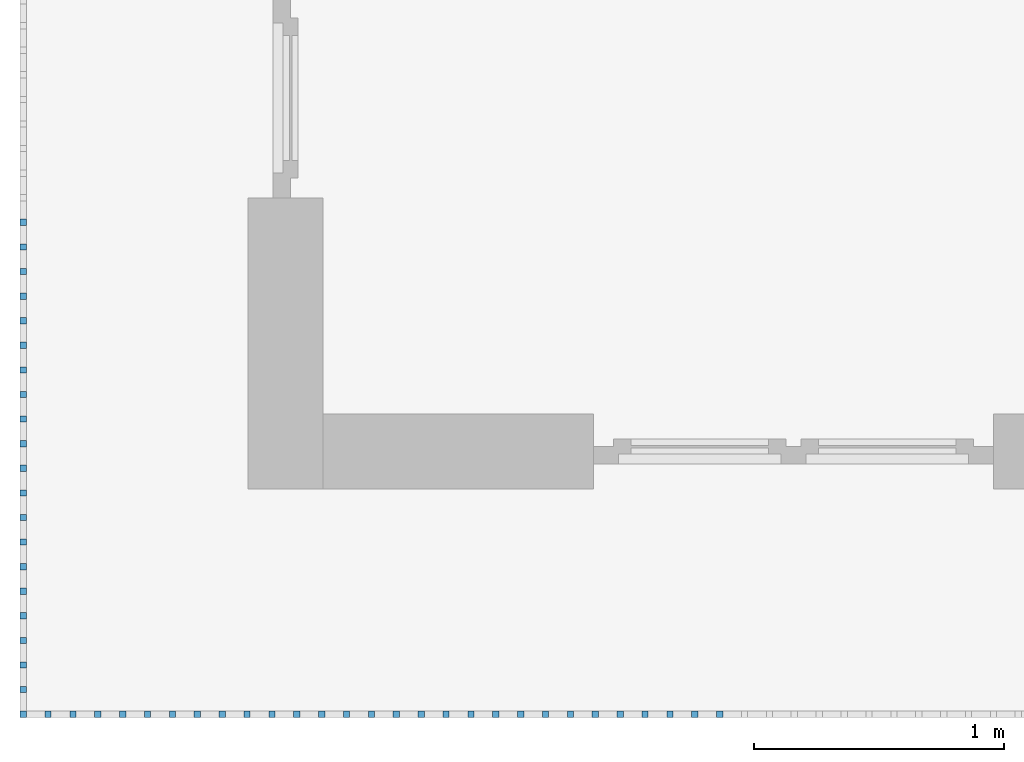
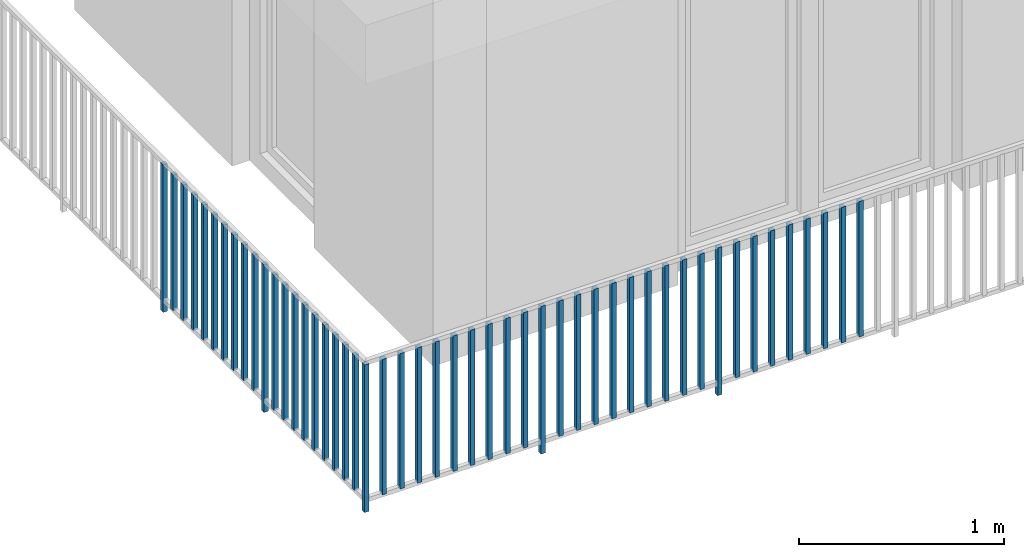
# One storey, part 32 of 54: 49 building element parts, 1 element without a shape of its own.
"""IFC4 building model written with IfcOpenShell, lengths in metres."""

from ifc_helpers import new_model, entity, si_unit, converted_unit, derived_unit, direction, frame, origin_with_axes, place, context, subcontext, project, spatial, polygons, material, type_object, element, aggregate, save


model = new_model("IFC4")

# Units and contexts
model_context = context("Model", 3, precision=1e-05, world=origin_with_axes(), true_north=direction((0.0, 1.0)))
body_context = subcontext(model_context, "Body", "Model", "MODEL_VIEW")
ifc_project = project(units=[si_unit("LENGTHUNIT", "METRE"), si_unit("AREAUNIT", "SQUARE_METRE"), si_unit("VOLUMEUNIT", "CUBIC_METRE"), converted_unit("PLANEANGLEUNIT", "DEGREE", entity("IfcPlaneAngleMeasure", 0.0174532925199), si_unit("PLANEANGLEUNIT", "RADIAN"), dimensions=[0, 0, 0, 0, 0, 0, 0]), converted_unit("TIMEUNIT", "Year", entity("IfcTimeMeasure", 31556926.0), si_unit("TIMEUNIT", "SECOND"), dimensions=[0, 0, 1, 0, 0, 0, 0]), si_unit("MASSUNIT", "GRAM", prefix="KILO"), si_unit("THERMODYNAMICTEMPERATUREUNIT", "DEGREE_CELSIUS"), si_unit("LUMINOUSINTENSITYUNIT", "LUMEN"), si_unit("ENERGYUNIT", "JOULE", prefix="MEGA"), derived_unit("THERMALCONDUCTANCEUNIT", [(si_unit("POWERUNIT", "WATT"), 1), (si_unit("LENGTHUNIT", "METRE"), -1), (si_unit("THERMODYNAMICTEMPERATUREUNIT", "KELVIN"), -1)]), derived_unit("SPECIFICHEATCAPACITYUNIT", [(si_unit("ENERGYUNIT", "JOULE"), 1), (si_unit("MASSUNIT", "GRAM", prefix="KILO"), -1), (si_unit("THERMODYNAMICTEMPERATUREUNIT", "KELVIN"), -1)]), derived_unit("MASSDENSITYUNIT", [(si_unit("MASSUNIT", "GRAM", prefix="KILO"), 1), (si_unit("VOLUMEUNIT", "CUBIC_METRE"), -1)])], contexts=[model_context])

# Site, building, storey, space
site_placement = place(None, origin_with_axes())
site = spatial("IfcSite", under=ifc_project, at=site_placement, CompositionType="ELEMENT")
building_placement = place(site_placement, origin_with_axes())
building = spatial("IfcBuilding", under=site, at=building_placement, CompositionType="ELEMENT")
storey_placement = place(building_placement, frame((0.0, 0.0, 9.18), z_axis=(0.0, 0.0, 1.0), x_axis=(1.0, 0.0, 0.0)))
storey = spatial("IfcBuildingStorey", under=building, at=storey_placement, Name="3. Geschoss", CompositionType="ELEMENT", Elevation=9.18)
space_placement = place(storey_placement, frame((10.2378006196, 9.82118769833, 0.0), z_axis=(0.0, 0.0, 1.0), x_axis=(-1.0, 0.0, 0.0)))
space = spatial("IfcSpace", under=storey, at=space_placement, CompositionType="ELEMENT", PredefinedType="EXTERNAL")

# Railing, building element parts
railing_type = type_object("IfcRailingType", PredefinedType="NOTDEFINED")
railing_placement = place(space_placement, frame((0.0, -7.06315681498e-08, 0.0), z_axis=(0.0, 0.0, 1.0), x_axis=(-1.0, 0.0, 0.0)))
railing = element("IfcRailing", 1, at=railing_placement, inside=space, type_object=railing_type, PredefinedType="NOTDEFINED")
ifc_material = material()
building_element_part_1_placement = place(railing_placement, origin_with_axes())
building_element_part_1 = element("IfcBuildingElementPart", 2, at=building_element_part_1_placement, material=ifc_material, PredefinedType="NOTDEFINED", context=body_context, shape_type="Tessellation", body=[
    polygons([(-22.8925, -20.6625, 0.0), (-22.8675, -20.6625, 0.0), (-22.8675, -20.6625, 0.88), (-22.8925, -20.6625, 0.88), (-22.8925, -20.6375, 0.0), (-22.8675, -20.6375, 0.0), (-22.8675, -20.6375, 0.88), (-22.8925, -20.6375, 0.88)], [[[1, 2, 3, 4]], [[1, 5, 6, 2]], [[2, 6, 7, 3]], [[4, 3, 7, 8]], [[5, 1, 4, 8]], [[6, 5, 8, 7]]], closed=True),
])
building_element_part_2_placement = place(railing_placement, origin_with_axes())
building_element_part_2 = element("IfcBuildingElementPart", 3, at=building_element_part_2_placement, material=ifc_material, PredefinedType="NOTDEFINED", context=body_context, shape_type="Tessellation", body=[
    polygons([(-22.8925, -18.6958333333, 0.0), (-22.8675, -18.6958333333, 0.0), (-22.8675, -18.6958333333, 0.88), (-22.8925, -18.6958333333, 0.88), (-22.8925, -18.6708333333, 0.0), (-22.8675, -18.6708333333, 0.0), (-22.8675, -18.6708333333, 0.88), (-22.8925, -18.6708333333, 0.88)], [[[1, 2, 3, 4]], [[1, 5, 6, 2]], [[2, 6, 7, 3]], [[4, 3, 7, 8]], [[5, 1, 4, 8]], [[6, 5, 8, 7]]], closed=True),
])
building_element_part_3_placement = place(railing_placement, origin_with_axes())
building_element_part_3 = element("IfcBuildingElementPart", 4, at=building_element_part_3_placement, material=ifc_material, PredefinedType="NOTDEFINED", context=body_context, shape_type="Tessellation", body=[
    polygons([(-22.8925, -18.7941666667, 0.07), (-22.8675, -18.7941666667, 0.07), (-22.8675, -18.7941666667, 0.8775), (-22.8925, -18.7941666667, 0.8775), (-22.8925, -18.7691666667, 0.07), (-22.8675, -18.7691666667, 0.07), (-22.8675, -18.7691666667, 0.8775), (-22.8925, -18.7691666667, 0.8775)], [[[1, 2, 3, 4]], [[1, 5, 6, 2]], [[2, 6, 7, 3]], [[4, 3, 7, 8]], [[5, 1, 4, 8]], [[6, 5, 8, 7]]], closed=True),
])
building_element_part_4_placement = place(railing_placement, origin_with_axes())
building_element_part_4 = element("IfcBuildingElementPart", 5, at=building_element_part_4_placement, material=ifc_material, PredefinedType="NOTDEFINED", context=body_context, shape_type="Tessellation", body=[
    polygons([(-22.8925, -18.8925, 0.07), (-22.8675, -18.8925, 0.07), (-22.8675, -18.8925, 0.8775), (-22.8925, -18.8925, 0.8775), (-22.8925, -18.8675, 0.07), (-22.8675, -18.8675, 0.07), (-22.8675, -18.8675, 0.8775), (-22.8925, -18.8675, 0.8775)], [[[1, 2, 3, 4]], [[1, 5, 6, 2]], [[2, 6, 7, 3]], [[4, 3, 7, 8]], [[5, 1, 4, 8]], [[6, 5, 8, 7]]], closed=True),
])
building_element_part_5_placement = place(railing_placement, origin_with_axes())
building_element_part_5 = element("IfcBuildingElementPart", 6, at=building_element_part_5_placement, material=ifc_material, PredefinedType="NOTDEFINED", context=body_context, shape_type="Tessellation", body=[
    polygons([(-22.8925, -18.9908333333, 0.07), (-22.8675, -18.9908333333, 0.07), (-22.8675, -18.9908333333, 0.8775), (-22.8925, -18.9908333333, 0.8775), (-22.8925, -18.9658333333, 0.07), (-22.8675, -18.9658333333, 0.07), (-22.8675, -18.9658333333, 0.8775), (-22.8925, -18.9658333333, 0.8775)], [[[1, 2, 3, 4]], [[1, 5, 6, 2]], [[2, 6, 7, 3]], [[4, 3, 7, 8]], [[5, 1, 4, 8]], [[6, 5, 8, 7]]], closed=True),
])
building_element_part_6_placement = place(railing_placement, origin_with_axes())
building_element_part_6 = element("IfcBuildingElementPart", 7, at=building_element_part_6_placement, material=ifc_material, PredefinedType="NOTDEFINED", context=body_context, shape_type="Tessellation", body=[
    polygons([(-22.8925, -19.0891666667, 0.07), (-22.8675, -19.0891666667, 0.07), (-22.8675, -19.0891666667, 0.8775), (-22.8925, -19.0891666667, 0.8775), (-22.8925, -19.0641666667, 0.07), (-22.8675, -19.0641666667, 0.07), (-22.8675, -19.0641666667, 0.8775), (-22.8925, -19.0641666667, 0.8775)], [[[1, 2, 3, 4]], [[1, 5, 6, 2]], [[2, 6, 7, 3]], [[4, 3, 7, 8]], [[5, 1, 4, 8]], [[6, 5, 8, 7]]], closed=True),
])
building_element_part_7_placement = place(railing_placement, origin_with_axes())
building_element_part_7 = element("IfcBuildingElementPart", 8, at=building_element_part_7_placement, material=ifc_material, PredefinedType="NOTDEFINED", context=body_context, shape_type="Tessellation", body=[
    polygons([(-22.8925, -19.1875, 0.07), (-22.8675, -19.1875, 0.07), (-22.8675, -19.1875, 0.8775), (-22.8925, -19.1875, 0.8775), (-22.8925, -19.1625, 0.07), (-22.8675, -19.1625, 0.07), (-22.8675, -19.1625, 0.8775), (-22.8925, -19.1625, 0.8775)], [[[1, 2, 3, 4]], [[1, 5, 6, 2]], [[2, 6, 7, 3]], [[4, 3, 7, 8]], [[5, 1, 4, 8]], [[6, 5, 8, 7]]], closed=True),
])
building_element_part_8_placement = place(railing_placement, origin_with_axes())
building_element_part_8 = element("IfcBuildingElementPart", 9, at=building_element_part_8_placement, material=ifc_material, PredefinedType="NOTDEFINED", context=body_context, shape_type="Tessellation", body=[
    polygons([(-22.8925, -19.2858333333, 0.07), (-22.8675, -19.2858333333, 0.07), (-22.8675, -19.2858333333, 0.8775), (-22.8925, -19.2858333333, 0.8775), (-22.8925, -19.2608333333, 0.07), (-22.8675, -19.2608333333, 0.07), (-22.8675, -19.2608333333, 0.8775), (-22.8925, -19.2608333333, 0.8775)], [[[1, 2, 3, 4]], [[1, 5, 6, 2]], [[2, 6, 7, 3]], [[4, 3, 7, 8]], [[5, 1, 4, 8]], [[6, 5, 8, 7]]], closed=True),
])
building_element_part_9_placement = place(railing_placement, origin_with_axes())
building_element_part_9 = element("IfcBuildingElementPart", 10, at=building_element_part_9_placement, material=ifc_material, PredefinedType="NOTDEFINED", context=body_context, shape_type="Tessellation", body=[
    polygons([(-22.8925, -19.3841666667, 0.07), (-22.8675, -19.3841666667, 0.07), (-22.8675, -19.3841666667, 0.8775), (-22.8925, -19.3841666667, 0.8775), (-22.8925, -19.3591666667, 0.07), (-22.8675, -19.3591666667, 0.07), (-22.8675, -19.3591666667, 0.8775), (-22.8925, -19.3591666667, 0.8775)], [[[1, 2, 3, 4]], [[1, 5, 6, 2]], [[2, 6, 7, 3]], [[4, 3, 7, 8]], [[5, 1, 4, 8]], [[6, 5, 8, 7]]], closed=True),
])
building_element_part_10_placement = place(railing_placement, origin_with_axes())
building_element_part_10 = element("IfcBuildingElementPart", 11, at=building_element_part_10_placement, material=ifc_material, PredefinedType="NOTDEFINED", context=body_context, shape_type="Tessellation", body=[
    polygons([(-22.8925, -19.4825, 0.07), (-22.8675, -19.4825, 0.07), (-22.8675, -19.4825, 0.8775), (-22.8925, -19.4825, 0.8775), (-22.8925, -19.4575, 0.07), (-22.8675, -19.4575, 0.07), (-22.8675, -19.4575, 0.8775), (-22.8925, -19.4575, 0.8775)], [[[1, 2, 3, 4]], [[1, 5, 6, 2]], [[2, 6, 7, 3]], [[4, 3, 7, 8]], [[5, 1, 4, 8]], [[6, 5, 8, 7]]], closed=True),
])
building_element_part_11_placement = place(railing_placement, origin_with_axes())
building_element_part_11 = element("IfcBuildingElementPart", 12, at=building_element_part_11_placement, material=ifc_material, PredefinedType="NOTDEFINED", context=body_context, shape_type="Tessellation", body=[
    polygons([(-22.8925, -19.5808333333, 0.07), (-22.8675, -19.5808333333, 0.07), (-22.8675, -19.5808333333, 0.8775), (-22.8925, -19.5808333333, 0.8775), (-22.8925, -19.5558333333, 0.07), (-22.8675, -19.5558333333, 0.07), (-22.8675, -19.5558333333, 0.8775), (-22.8925, -19.5558333333, 0.8775)], [[[1, 2, 3, 4]], [[1, 5, 6, 2]], [[2, 6, 7, 3]], [[4, 3, 7, 8]], [[5, 1, 4, 8]], [[6, 5, 8, 7]]], closed=True),
])
building_element_part_12_placement = place(railing_placement, origin_with_axes())
building_element_part_12 = element("IfcBuildingElementPart", 13, at=building_element_part_12_placement, material=ifc_material, PredefinedType="NOTDEFINED", context=body_context, shape_type="Tessellation", body=[
    polygons([(-22.8925, -19.6791666667, 0.0), (-22.8675, -19.6791666667, 0.0), (-22.8675, -19.6791666667, 0.88), (-22.8925, -19.6791666667, 0.88), (-22.8925, -19.6541666667, 0.0), (-22.8675, -19.6541666667, 0.0), (-22.8675, -19.6541666667, 0.88), (-22.8925, -19.6541666667, 0.88)], [[[1, 2, 3, 4]], [[1, 5, 6, 2]], [[2, 6, 7, 3]], [[4, 3, 7, 8]], [[5, 1, 4, 8]], [[6, 5, 8, 7]]], closed=True),
])
building_element_part_13_placement = place(railing_placement, origin_with_axes())
building_element_part_13 = element("IfcBuildingElementPart", 14, at=building_element_part_13_placement, material=ifc_material, PredefinedType="NOTDEFINED", context=body_context, shape_type="Tessellation", body=[
    polygons([(-22.8925, -19.7775, 0.07), (-22.8675, -19.7775, 0.07), (-22.8675, -19.7775, 0.8775), (-22.8925, -19.7775, 0.8775), (-22.8925, -19.7525, 0.07), (-22.8675, -19.7525, 0.07), (-22.8675, -19.7525, 0.8775), (-22.8925, -19.7525, 0.8775)], [[[1, 2, 3, 4]], [[1, 5, 6, 2]], [[2, 6, 7, 3]], [[4, 3, 7, 8]], [[5, 1, 4, 8]], [[6, 5, 8, 7]]], closed=True),
])
building_element_part_14_placement = place(railing_placement, origin_with_axes())
building_element_part_14 = element("IfcBuildingElementPart", 15, at=building_element_part_14_placement, material=ifc_material, PredefinedType="NOTDEFINED", context=body_context, shape_type="Tessellation", body=[
    polygons([(-22.8925, -19.8758333333, 0.07), (-22.8675, -19.8758333333, 0.07), (-22.8675, -19.8758333333, 0.8775), (-22.8925, -19.8758333333, 0.8775), (-22.8925, -19.8508333333, 0.07), (-22.8675, -19.8508333333, 0.07), (-22.8675, -19.8508333333, 0.8775), (-22.8925, -19.8508333333, 0.8775)], [[[1, 2, 3, 4]], [[1, 5, 6, 2]], [[2, 6, 7, 3]], [[4, 3, 7, 8]], [[5, 1, 4, 8]], [[6, 5, 8, 7]]], closed=True),
])
building_element_part_15_placement = place(railing_placement, origin_with_axes())
building_element_part_15 = element("IfcBuildingElementPart", 16, at=building_element_part_15_placement, material=ifc_material, PredefinedType="NOTDEFINED", context=body_context, shape_type="Tessellation", body=[
    polygons([(-22.8925, -19.9741666667, 0.07), (-22.8675, -19.9741666667, 0.07), (-22.8675, -19.9741666667, 0.8775), (-22.8925, -19.9741666667, 0.8775), (-22.8925, -19.9491666667, 0.07), (-22.8675, -19.9491666667, 0.07), (-22.8675, -19.9491666667, 0.8775), (-22.8925, -19.9491666667, 0.8775)], [[[1, 2, 3, 4]], [[1, 5, 6, 2]], [[2, 6, 7, 3]], [[4, 3, 7, 8]], [[5, 1, 4, 8]], [[6, 5, 8, 7]]], closed=True),
])
building_element_part_16_placement = place(railing_placement, origin_with_axes())
building_element_part_16 = element("IfcBuildingElementPart", 17, at=building_element_part_16_placement, material=ifc_material, PredefinedType="NOTDEFINED", context=body_context, shape_type="Tessellation", body=[
    polygons([(-22.8925, -20.0725, 0.07), (-22.8675, -20.0725, 0.07), (-22.8675, -20.0725, 0.8775), (-22.8925, -20.0725, 0.8775), (-22.8925, -20.0475, 0.07), (-22.8675, -20.0475, 0.07), (-22.8675, -20.0475, 0.8775), (-22.8925, -20.0475, 0.8775)], [[[1, 2, 3, 4]], [[1, 5, 6, 2]], [[2, 6, 7, 3]], [[4, 3, 7, 8]], [[5, 1, 4, 8]], [[6, 5, 8, 7]]], closed=True),
])
building_element_part_17_placement = place(railing_placement, origin_with_axes())
building_element_part_17 = element("IfcBuildingElementPart", 18, at=building_element_part_17_placement, material=ifc_material, PredefinedType="NOTDEFINED", context=body_context, shape_type="Tessellation", body=[
    polygons([(-22.8925, -20.1708333333, 0.07), (-22.8675, -20.1708333333, 0.07), (-22.8675, -20.1708333333, 0.8775), (-22.8925, -20.1708333333, 0.8775), (-22.8925, -20.1458333333, 0.07), (-22.8675, -20.1458333333, 0.07), (-22.8675, -20.1458333333, 0.8775), (-22.8925, -20.1458333333, 0.8775)], [[[1, 2, 3, 4]], [[1, 5, 6, 2]], [[2, 6, 7, 3]], [[4, 3, 7, 8]], [[5, 1, 4, 8]], [[6, 5, 8, 7]]], closed=True),
])
building_element_part_18_placement = place(railing_placement, origin_with_axes())
building_element_part_18 = element("IfcBuildingElementPart", 19, at=building_element_part_18_placement, material=ifc_material, PredefinedType="NOTDEFINED", context=body_context, shape_type="Tessellation", body=[
    polygons([(-22.8925, -20.2691666667, 0.07), (-22.8675, -20.2691666667, 0.07), (-22.8675, -20.2691666667, 0.8775), (-22.8925, -20.2691666667, 0.8775), (-22.8925, -20.2441666667, 0.07), (-22.8675, -20.2441666667, 0.07), (-22.8675, -20.2441666667, 0.8775), (-22.8925, -20.2441666667, 0.8775)], [[[1, 2, 3, 4]], [[1, 5, 6, 2]], [[2, 6, 7, 3]], [[4, 3, 7, 8]], [[5, 1, 4, 8]], [[6, 5, 8, 7]]], closed=True),
])
building_element_part_19_placement = place(railing_placement, origin_with_axes())
building_element_part_19 = element("IfcBuildingElementPart", 20, at=building_element_part_19_placement, material=ifc_material, PredefinedType="NOTDEFINED", context=body_context, shape_type="Tessellation", body=[
    polygons([(-22.8925, -20.3675, 0.07), (-22.8675, -20.3675, 0.07), (-22.8675, -20.3675, 0.8775), (-22.8925, -20.3675, 0.8775), (-22.8925, -20.3425, 0.07), (-22.8675, -20.3425, 0.07), (-22.8675, -20.3425, 0.8775), (-22.8925, -20.3425, 0.8775)], [[[1, 2, 3, 4]], [[1, 5, 6, 2]], [[2, 6, 7, 3]], [[4, 3, 7, 8]], [[5, 1, 4, 8]], [[6, 5, 8, 7]]], closed=True),
])
building_element_part_20_placement = place(railing_placement, origin_with_axes())
building_element_part_20 = element("IfcBuildingElementPart", 21, at=building_element_part_20_placement, material=ifc_material, PredefinedType="NOTDEFINED", context=body_context, shape_type="Tessellation", body=[
    polygons([(-22.8925, -20.4658333333, 0.07), (-22.8675, -20.4658333333, 0.07), (-22.8675, -20.4658333333, 0.8775), (-22.8925, -20.4658333333, 0.8775), (-22.8925, -20.4408333333, 0.07), (-22.8675, -20.4408333333, 0.07), (-22.8675, -20.4408333333, 0.8775), (-22.8925, -20.4408333333, 0.8775)], [[[1, 2, 3, 4]], [[1, 5, 6, 2]], [[2, 6, 7, 3]], [[4, 3, 7, 8]], [[5, 1, 4, 8]], [[6, 5, 8, 7]]], closed=True),
])
building_element_part_21_placement = place(railing_placement, origin_with_axes())
building_element_part_21 = element("IfcBuildingElementPart", 22, at=building_element_part_21_placement, material=ifc_material, PredefinedType="NOTDEFINED", context=body_context, shape_type="Tessellation", body=[
    polygons([(-22.8925, -20.5641666667, 0.07), (-22.8675, -20.5641666667, 0.07), (-22.8675, -20.5641666667, 0.8775), (-22.8925, -20.5641666667, 0.8775), (-22.8925, -20.5391666667, 0.07), (-22.8675, -20.5391666667, 0.07), (-22.8675, -20.5391666667, 0.8775), (-22.8925, -20.5391666667, 0.8775)], [[[1, 2, 3, 4]], [[1, 5, 6, 2]], [[2, 6, 7, 3]], [[4, 3, 7, 8]], [[5, 1, 4, 8]], [[6, 5, 8, 7]]], closed=True),
])
building_element_part_22_placement = place(railing_placement, origin_with_axes())
building_element_part_22 = element("IfcBuildingElementPart", 23, at=building_element_part_22_placement, material=ifc_material, PredefinedType="NOTDEFINED", context=body_context, shape_type="Tessellation", body=[
    polygons([(-22.7680217391, -20.6625, 0.07), (-22.7680217391, -20.6375, 0.07), (-22.7680217391, -20.6375, 0.8775), (-22.7680217391, -20.6625, 0.8775), (-22.7930217391, -20.6625, 0.07), (-22.7930217391, -20.6375, 0.07), (-22.7930217391, -20.6375, 0.8775), (-22.7930217391, -20.6625, 0.8775)], [[[1, 2, 3, 4]], [[1, 5, 6, 2]], [[2, 6, 7, 3]], [[4, 3, 7, 8]], [[5, 1, 4, 8]], [[6, 5, 8, 7]]], closed=True),
])
building_element_part_23_placement = place(railing_placement, origin_with_axes())
building_element_part_23 = element("IfcBuildingElementPart", 24, at=building_element_part_23_placement, material=ifc_material, PredefinedType="NOTDEFINED", context=body_context, shape_type="Tessellation", body=[
    polygons([(-22.6685434783, -20.6625, 0.07), (-22.6685434783, -20.6375, 0.07), (-22.6685434783, -20.6375, 0.8775), (-22.6685434783, -20.6625, 0.8775), (-22.6935434783, -20.6625, 0.07), (-22.6935434783, -20.6375, 0.07), (-22.6935434783, -20.6375, 0.8775), (-22.6935434783, -20.6625, 0.8775)], [[[1, 2, 3, 4]], [[1, 5, 6, 2]], [[2, 6, 7, 3]], [[4, 3, 7, 8]], [[5, 1, 4, 8]], [[6, 5, 8, 7]]], closed=True),
])
building_element_part_24_placement = place(railing_placement, origin_with_axes())
building_element_part_24 = element("IfcBuildingElementPart", 25, at=building_element_part_24_placement, material=ifc_material, PredefinedType="NOTDEFINED", context=body_context, shape_type="Tessellation", body=[
    polygons([(-22.5690652174, -20.6625, 0.07), (-22.5690652174, -20.6375, 0.07), (-22.5690652174, -20.6375, 0.8775), (-22.5690652174, -20.6625, 0.8775), (-22.5940652174, -20.6625, 0.07), (-22.5940652174, -20.6375, 0.07), (-22.5940652174, -20.6375, 0.8775), (-22.5940652174, -20.6625, 0.8775)], [[[1, 2, 3, 4]], [[1, 5, 6, 2]], [[2, 6, 7, 3]], [[4, 3, 7, 8]], [[5, 1, 4, 8]], [[6, 5, 8, 7]]], closed=True),
])
building_element_part_25_placement = place(railing_placement, origin_with_axes())
building_element_part_25 = element("IfcBuildingElementPart", 26, at=building_element_part_25_placement, material=ifc_material, PredefinedType="NOTDEFINED", context=body_context, shape_type="Tessellation", body=[
    polygons([(-22.4695869565, -20.6625, 0.07), (-22.4695869565, -20.6375, 0.07), (-22.4695869565, -20.6375, 0.8775), (-22.4695869565, -20.6625, 0.8775), (-22.4945869565, -20.6625, 0.07), (-22.4945869565, -20.6375, 0.07), (-22.4945869565, -20.6375, 0.8775), (-22.4945869565, -20.6625, 0.8775)], [[[1, 2, 3, 4]], [[1, 5, 6, 2]], [[2, 6, 7, 3]], [[4, 3, 7, 8]], [[5, 1, 4, 8]], [[6, 5, 8, 7]]], closed=True),
])
building_element_part_26_placement = place(railing_placement, origin_with_axes())
building_element_part_26 = element("IfcBuildingElementPart", 27, at=building_element_part_26_placement, material=ifc_material, PredefinedType="NOTDEFINED", context=body_context, shape_type="Tessellation", body=[
    polygons([(-22.3701086957, -20.6625, 0.07), (-22.3701086957, -20.6375, 0.07), (-22.3701086957, -20.6375, 0.8775), (-22.3701086957, -20.6625, 0.8775), (-22.3951086957, -20.6625, 0.07), (-22.3951086957, -20.6375, 0.07), (-22.3951086957, -20.6375, 0.8775), (-22.3951086957, -20.6625, 0.8775)], [[[1, 2, 3, 4]], [[1, 5, 6, 2]], [[2, 6, 7, 3]], [[4, 3, 7, 8]], [[5, 1, 4, 8]], [[6, 5, 8, 7]]], closed=True),
])
building_element_part_27_placement = place(railing_placement, origin_with_axes())
building_element_part_27 = element("IfcBuildingElementPart", 28, at=building_element_part_27_placement, material=ifc_material, PredefinedType="NOTDEFINED", context=body_context, shape_type="Tessellation", body=[
    polygons([(-22.2706304348, -20.6625, 0.07), (-22.2706304348, -20.6375, 0.07), (-22.2706304348, -20.6375, 0.8775), (-22.2706304348, -20.6625, 0.8775), (-22.2956304348, -20.6625, 0.07), (-22.2956304348, -20.6375, 0.07), (-22.2956304348, -20.6375, 0.8775), (-22.2956304348, -20.6625, 0.8775)], [[[1, 2, 3, 4]], [[1, 5, 6, 2]], [[2, 6, 7, 3]], [[4, 3, 7, 8]], [[5, 1, 4, 8]], [[6, 5, 8, 7]]], closed=True),
])
building_element_part_28_placement = place(railing_placement, origin_with_axes())
building_element_part_28 = element("IfcBuildingElementPart", 29, at=building_element_part_28_placement, material=ifc_material, PredefinedType="NOTDEFINED", context=body_context, shape_type="Tessellation", body=[
    polygons([(-22.1711521739, -20.6625, 0.07), (-22.1711521739, -20.6375, 0.07), (-22.1711521739, -20.6375, 0.8775), (-22.1711521739, -20.6625, 0.8775), (-22.1961521739, -20.6625, 0.07), (-22.1961521739, -20.6375, 0.07), (-22.1961521739, -20.6375, 0.8775), (-22.1961521739, -20.6625, 0.8775)], [[[1, 2, 3, 4]], [[1, 5, 6, 2]], [[2, 6, 7, 3]], [[4, 3, 7, 8]], [[5, 1, 4, 8]], [[6, 5, 8, 7]]], closed=True),
])
building_element_part_29_placement = place(railing_placement, origin_with_axes())
building_element_part_29 = element("IfcBuildingElementPart", 30, at=building_element_part_29_placement, material=ifc_material, PredefinedType="NOTDEFINED", context=body_context, shape_type="Tessellation", body=[
    polygons([(-22.071673913, -20.6625, 0.07), (-22.071673913, -20.6375, 0.07), (-22.071673913, -20.6375, 0.8775), (-22.071673913, -20.6625, 0.8775), (-22.096673913, -20.6625, 0.07), (-22.096673913, -20.6375, 0.07), (-22.096673913, -20.6375, 0.8775), (-22.096673913, -20.6625, 0.8775)], [[[1, 2, 3, 4]], [[1, 5, 6, 2]], [[2, 6, 7, 3]], [[4, 3, 7, 8]], [[5, 1, 4, 8]], [[6, 5, 8, 7]]], closed=True),
])
building_element_part_30_placement = place(railing_placement, origin_with_axes())
building_element_part_30 = element("IfcBuildingElementPart", 31, at=building_element_part_30_placement, material=ifc_material, PredefinedType="NOTDEFINED", context=body_context, shape_type="Tessellation", body=[
    polygons([(-21.9721956522, -20.6625, 0.07), (-21.9721956522, -20.6375, 0.07), (-21.9721956522, -20.6375, 0.8775), (-21.9721956522, -20.6625, 0.8775), (-21.9971956522, -20.6625, 0.07), (-21.9971956522, -20.6375, 0.07), (-21.9971956522, -20.6375, 0.8775), (-21.9971956522, -20.6625, 0.8775)], [[[1, 2, 3, 4]], [[1, 5, 6, 2]], [[2, 6, 7, 3]], [[4, 3, 7, 8]], [[5, 1, 4, 8]], [[6, 5, 8, 7]]], closed=True),
])
building_element_part_31_placement = place(railing_placement, origin_with_axes())
building_element_part_31 = element("IfcBuildingElementPart", 32, at=building_element_part_31_placement, material=ifc_material, PredefinedType="NOTDEFINED", context=body_context, shape_type="Tessellation", body=[
    polygons([(-21.8727173913, -20.6625, 0.0), (-21.8727173913, -20.6375, 0.0), (-21.8727173913, -20.6375, 0.88), (-21.8727173913, -20.6625, 0.88), (-21.8977173913, -20.6625, 0.0), (-21.8977173913, -20.6375, 0.0), (-21.8977173913, -20.6375, 0.88), (-21.8977173913, -20.6625, 0.88)], [[[1, 2, 3, 4]], [[1, 5, 6, 2]], [[2, 6, 7, 3]], [[4, 3, 7, 8]], [[5, 1, 4, 8]], [[6, 5, 8, 7]]], closed=True),
])
building_element_part_32_placement = place(railing_placement, origin_with_axes())
building_element_part_32 = element("IfcBuildingElementPart", 33, at=building_element_part_32_placement, material=ifc_material, PredefinedType="NOTDEFINED", context=body_context, shape_type="Tessellation", body=[
    polygons([(-21.7732391304, -20.6625, 0.07), (-21.7732391304, -20.6375, 0.07), (-21.7732391304, -20.6375, 0.8775), (-21.7732391304, -20.6625, 0.8775), (-21.7982391304, -20.6625, 0.07), (-21.7982391304, -20.6375, 0.07), (-21.7982391304, -20.6375, 0.8775), (-21.7982391304, -20.6625, 0.8775)], [[[1, 2, 3, 4]], [[1, 5, 6, 2]], [[2, 6, 7, 3]], [[4, 3, 7, 8]], [[5, 1, 4, 8]], [[6, 5, 8, 7]]], closed=True),
])
building_element_part_33_placement = place(railing_placement, origin_with_axes())
building_element_part_33 = element("IfcBuildingElementPart", 34, at=building_element_part_33_placement, material=ifc_material, PredefinedType="NOTDEFINED", context=body_context, shape_type="Tessellation", body=[
    polygons([(-21.6737608696, -20.6625, 0.07), (-21.6737608696, -20.6375, 0.07), (-21.6737608696, -20.6375, 0.8775), (-21.6737608696, -20.6625, 0.8775), (-21.6987608696, -20.6625, 0.07), (-21.6987608696, -20.6375, 0.07), (-21.6987608696, -20.6375, 0.8775), (-21.6987608696, -20.6625, 0.8775)], [[[1, 2, 3, 4]], [[1, 5, 6, 2]], [[2, 6, 7, 3]], [[4, 3, 7, 8]], [[5, 1, 4, 8]], [[6, 5, 8, 7]]], closed=True),
])
building_element_part_34_placement = place(railing_placement, origin_with_axes())
building_element_part_34 = element("IfcBuildingElementPart", 35, at=building_element_part_34_placement, material=ifc_material, PredefinedType="NOTDEFINED", context=body_context, shape_type="Tessellation", body=[
    polygons([(-21.5742826087, -20.6625, 0.07), (-21.5742826087, -20.6375, 0.07), (-21.5742826087, -20.6375, 0.8775), (-21.5742826087, -20.6625, 0.8775), (-21.5992826087, -20.6625, 0.07), (-21.5992826087, -20.6375, 0.07), (-21.5992826087, -20.6375, 0.8775), (-21.5992826087, -20.6625, 0.8775)], [[[1, 2, 3, 4]], [[1, 5, 6, 2]], [[2, 6, 7, 3]], [[4, 3, 7, 8]], [[5, 1, 4, 8]], [[6, 5, 8, 7]]], closed=True),
])
building_element_part_35_placement = place(railing_placement, origin_with_axes())
building_element_part_35 = element("IfcBuildingElementPart", 36, at=building_element_part_35_placement, material=ifc_material, PredefinedType="NOTDEFINED", context=body_context, shape_type="Tessellation", body=[
    polygons([(-21.4748043478, -20.6625, 0.07), (-21.4748043478, -20.6375, 0.07), (-21.4748043478, -20.6375, 0.8775), (-21.4748043478, -20.6625, 0.8775), (-21.4998043478, -20.6625, 0.07), (-21.4998043478, -20.6375, 0.07), (-21.4998043478, -20.6375, 0.8775), (-21.4998043478, -20.6625, 0.8775)], [[[1, 2, 3, 4]], [[1, 5, 6, 2]], [[2, 6, 7, 3]], [[4, 3, 7, 8]], [[5, 1, 4, 8]], [[6, 5, 8, 7]]], closed=True),
])
building_element_part_36_placement = place(railing_placement, origin_with_axes())
building_element_part_36 = element("IfcBuildingElementPart", 37, at=building_element_part_36_placement, material=ifc_material, PredefinedType="NOTDEFINED", context=body_context, shape_type="Tessellation", body=[
    polygons([(-21.375326087, -20.6625, 0.07), (-21.375326087, -20.6375, 0.07), (-21.375326087, -20.6375, 0.8775), (-21.375326087, -20.6625, 0.8775), (-21.400326087, -20.6625, 0.07), (-21.400326087, -20.6375, 0.07), (-21.400326087, -20.6375, 0.8775), (-21.400326087, -20.6625, 0.8775)], [[[1, 2, 3, 4]], [[1, 5, 6, 2]], [[2, 6, 7, 3]], [[4, 3, 7, 8]], [[5, 1, 4, 8]], [[6, 5, 8, 7]]], closed=True),
])
building_element_part_37_placement = place(railing_placement, origin_with_axes())
building_element_part_37 = element("IfcBuildingElementPart", 38, at=building_element_part_37_placement, material=ifc_material, PredefinedType="NOTDEFINED", context=body_context, shape_type="Tessellation", body=[
    polygons([(-21.2758478261, -20.6625, 0.07), (-21.2758478261, -20.6375, 0.07), (-21.2758478261, -20.6375, 0.8775), (-21.2758478261, -20.6625, 0.8775), (-21.3008478261, -20.6625, 0.07), (-21.3008478261, -20.6375, 0.07), (-21.3008478261, -20.6375, 0.8775), (-21.3008478261, -20.6625, 0.8775)], [[[1, 2, 3, 4]], [[1, 5, 6, 2]], [[2, 6, 7, 3]], [[4, 3, 7, 8]], [[5, 1, 4, 8]], [[6, 5, 8, 7]]], closed=True),
])
building_element_part_38_placement = place(railing_placement, origin_with_axes())
building_element_part_38 = element("IfcBuildingElementPart", 39, at=building_element_part_38_placement, material=ifc_material, PredefinedType="NOTDEFINED", context=body_context, shape_type="Tessellation", body=[
    polygons([(-21.1763695652, -20.6625, 0.07), (-21.1763695652, -20.6375, 0.07), (-21.1763695652, -20.6375, 0.8775), (-21.1763695652, -20.6625, 0.8775), (-21.2013695652, -20.6625, 0.07), (-21.2013695652, -20.6375, 0.07), (-21.2013695652, -20.6375, 0.8775), (-21.2013695652, -20.6625, 0.8775)], [[[1, 2, 3, 4]], [[1, 5, 6, 2]], [[2, 6, 7, 3]], [[4, 3, 7, 8]], [[5, 1, 4, 8]], [[6, 5, 8, 7]]], closed=True),
])
building_element_part_39_placement = place(railing_placement, origin_with_axes())
building_element_part_39 = element("IfcBuildingElementPart", 40, at=building_element_part_39_placement, material=ifc_material, PredefinedType="NOTDEFINED", context=body_context, shape_type="Tessellation", body=[
    polygons([(-21.0768913043, -20.6625, 0.07), (-21.0768913043, -20.6375, 0.07), (-21.0768913043, -20.6375, 0.8775), (-21.0768913043, -20.6625, 0.8775), (-21.1018913043, -20.6625, 0.07), (-21.1018913043, -20.6375, 0.07), (-21.1018913043, -20.6375, 0.8775), (-21.1018913043, -20.6625, 0.8775)], [[[1, 2, 3, 4]], [[1, 5, 6, 2]], [[2, 6, 7, 3]], [[4, 3, 7, 8]], [[5, 1, 4, 8]], [[6, 5, 8, 7]]], closed=True),
])
building_element_part_40_placement = place(railing_placement, origin_with_axes())
building_element_part_40 = element("IfcBuildingElementPart", 41, at=building_element_part_40_placement, material=ifc_material, PredefinedType="NOTDEFINED", context=body_context, shape_type="Tessellation", body=[
    polygons([(-20.9774130435, -20.6625, 0.07), (-20.9774130435, -20.6375, 0.07), (-20.9774130435, -20.6375, 0.8775), (-20.9774130435, -20.6625, 0.8775), (-21.0024130435, -20.6625, 0.07), (-21.0024130435, -20.6375, 0.07), (-21.0024130435, -20.6375, 0.8775), (-21.0024130435, -20.6625, 0.8775)], [[[1, 2, 3, 4]], [[1, 5, 6, 2]], [[2, 6, 7, 3]], [[4, 3, 7, 8]], [[5, 1, 4, 8]], [[6, 5, 8, 7]]], closed=True),
])
building_element_part_41_placement = place(railing_placement, origin_with_axes())
building_element_part_41 = element("IfcBuildingElementPart", 42, at=building_element_part_41_placement, material=ifc_material, PredefinedType="NOTDEFINED", context=body_context, shape_type="Tessellation", body=[
    polygons([(-20.8779347826, -20.6625, 0.0), (-20.8779347826, -20.6375, 0.0), (-20.8779347826, -20.6375, 0.88), (-20.8779347826, -20.6625, 0.88), (-20.9029347826, -20.6625, 0.0), (-20.9029347826, -20.6375, 0.0), (-20.9029347826, -20.6375, 0.88), (-20.9029347826, -20.6625, 0.88)], [[[1, 2, 3, 4]], [[1, 5, 6, 2]], [[2, 6, 7, 3]], [[4, 3, 7, 8]], [[5, 1, 4, 8]], [[6, 5, 8, 7]]], closed=True),
])
building_element_part_42_placement = place(railing_placement, origin_with_axes())
building_element_part_42 = element("IfcBuildingElementPart", 43, at=building_element_part_42_placement, material=ifc_material, PredefinedType="NOTDEFINED", context=body_context, shape_type="Tessellation", body=[
    polygons([(-20.7784565217, -20.6625, 0.07), (-20.7784565217, -20.6375, 0.07), (-20.7784565217, -20.6375, 0.8775), (-20.7784565217, -20.6625, 0.8775), (-20.8034565217, -20.6625, 0.07), (-20.8034565217, -20.6375, 0.07), (-20.8034565217, -20.6375, 0.8775), (-20.8034565217, -20.6625, 0.8775)], [[[1, 2, 3, 4]], [[1, 5, 6, 2]], [[2, 6, 7, 3]], [[4, 3, 7, 8]], [[5, 1, 4, 8]], [[6, 5, 8, 7]]], closed=True),
])
building_element_part_43_placement = place(railing_placement, origin_with_axes())
building_element_part_43 = element("IfcBuildingElementPart", 44, at=building_element_part_43_placement, material=ifc_material, PredefinedType="NOTDEFINED", context=body_context, shape_type="Tessellation", body=[
    polygons([(-20.6789782609, -20.6625, 0.07), (-20.6789782609, -20.6375, 0.07), (-20.6789782609, -20.6375, 0.8775), (-20.6789782609, -20.6625, 0.8775), (-20.7039782609, -20.6625, 0.07), (-20.7039782609, -20.6375, 0.07), (-20.7039782609, -20.6375, 0.8775), (-20.7039782609, -20.6625, 0.8775)], [[[1, 2, 3, 4]], [[1, 5, 6, 2]], [[2, 6, 7, 3]], [[4, 3, 7, 8]], [[5, 1, 4, 8]], [[6, 5, 8, 7]]], closed=True),
])
building_element_part_44_placement = place(railing_placement, origin_with_axes())
building_element_part_44 = element("IfcBuildingElementPart", 45, at=building_element_part_44_placement, material=ifc_material, PredefinedType="NOTDEFINED", context=body_context, shape_type="Tessellation", body=[
    polygons([(-20.5795, -20.6625, 0.07), (-20.5795, -20.6375, 0.07), (-20.5795, -20.6375, 0.8775), (-20.5795, -20.6625, 0.8775), (-20.6045, -20.6625, 0.07), (-20.6045, -20.6375, 0.07), (-20.6045, -20.6375, 0.8775), (-20.6045, -20.6625, 0.8775)], [[[1, 2, 3, 4]], [[1, 5, 6, 2]], [[2, 6, 7, 3]], [[4, 3, 7, 8]], [[5, 1, 4, 8]], [[6, 5, 8, 7]]], closed=True),
])
building_element_part_45_placement = place(railing_placement, origin_with_axes())
building_element_part_45 = element("IfcBuildingElementPart", 46, at=building_element_part_45_placement, material=ifc_material, PredefinedType="NOTDEFINED", context=body_context, shape_type="Tessellation", body=[
    polygons([(-20.4800217391, -20.6625, 0.07), (-20.4800217391, -20.6375, 0.07), (-20.4800217391, -20.6375, 0.8775), (-20.4800217391, -20.6625, 0.8775), (-20.5050217391, -20.6625, 0.07), (-20.5050217391, -20.6375, 0.07), (-20.5050217391, -20.6375, 0.8775), (-20.5050217391, -20.6625, 0.8775)], [[[1, 2, 3, 4]], [[1, 5, 6, 2]], [[2, 6, 7, 3]], [[4, 3, 7, 8]], [[5, 1, 4, 8]], [[6, 5, 8, 7]]], closed=True),
])
building_element_part_46_placement = place(railing_placement, origin_with_axes())
building_element_part_46 = element("IfcBuildingElementPart", 47, at=building_element_part_46_placement, material=ifc_material, PredefinedType="NOTDEFINED", context=body_context, shape_type="Tessellation", body=[
    polygons([(-20.3805434783, -20.6625, 0.07), (-20.3805434783, -20.6375, 0.07), (-20.3805434783, -20.6375, 0.8775), (-20.3805434783, -20.6625, 0.8775), (-20.4055434783, -20.6625, 0.07), (-20.4055434783, -20.6375, 0.07), (-20.4055434783, -20.6375, 0.8775), (-20.4055434783, -20.6625, 0.8775)], [[[1, 2, 3, 4]], [[1, 5, 6, 2]], [[2, 6, 7, 3]], [[4, 3, 7, 8]], [[5, 1, 4, 8]], [[6, 5, 8, 7]]], closed=True),
])
building_element_part_47_placement = place(railing_placement, origin_with_axes())
building_element_part_47 = element("IfcBuildingElementPart", 48, at=building_element_part_47_placement, material=ifc_material, PredefinedType="NOTDEFINED", context=body_context, shape_type="Tessellation", body=[
    polygons([(-20.2810652174, -20.6625, 0.07), (-20.2810652174, -20.6375, 0.07), (-20.2810652174, -20.6375, 0.8775), (-20.2810652174, -20.6625, 0.8775), (-20.3060652174, -20.6625, 0.07), (-20.3060652174, -20.6375, 0.07), (-20.3060652174, -20.6375, 0.8775), (-20.3060652174, -20.6625, 0.8775)], [[[1, 2, 3, 4]], [[1, 5, 6, 2]], [[2, 6, 7, 3]], [[4, 3, 7, 8]], [[5, 1, 4, 8]], [[6, 5, 8, 7]]], closed=True),
])
building_element_part_48_placement = place(railing_placement, origin_with_axes())
building_element_part_48 = element("IfcBuildingElementPart", 49, at=building_element_part_48_placement, material=ifc_material, PredefinedType="NOTDEFINED", context=body_context, shape_type="Tessellation", body=[
    polygons([(-20.1815869565, -20.6625, 0.07), (-20.1815869565, -20.6375, 0.07), (-20.1815869565, -20.6375, 0.8775), (-20.1815869565, -20.6625, 0.8775), (-20.2065869565, -20.6625, 0.07), (-20.2065869565, -20.6375, 0.07), (-20.2065869565, -20.6375, 0.8775), (-20.2065869565, -20.6625, 0.8775)], [[[1, 2, 3, 4]], [[1, 5, 6, 2]], [[2, 6, 7, 3]], [[4, 3, 7, 8]], [[5, 1, 4, 8]], [[6, 5, 8, 7]]], closed=True),
])
building_element_part_49_placement = place(railing_placement, origin_with_axes())
building_element_part_49 = element("IfcBuildingElementPart", 50, at=building_element_part_49_placement, material=ifc_material, PredefinedType="NOTDEFINED", context=body_context, shape_type="Tessellation", body=[
    polygons([(-20.0821086957, -20.6625, 0.07), (-20.0821086957, -20.6375, 0.07), (-20.0821086957, -20.6375, 0.8775), (-20.0821086957, -20.6625, 0.8775), (-20.1071086957, -20.6625, 0.07), (-20.1071086957, -20.6375, 0.07), (-20.1071086957, -20.6375, 0.8775), (-20.1071086957, -20.6625, 0.8775)], [[[1, 2, 3, 4]], [[1, 5, 6, 2]], [[2, 6, 7, 3]], [[4, 3, 7, 8]], [[5, 1, 4, 8]], [[6, 5, 8, 7]]], closed=True),
])
aggregate(railing, [building_element_part_1, building_element_part_2, building_element_part_3, building_element_part_4, building_element_part_5, building_element_part_6, building_element_part_7, building_element_part_8, building_element_part_9, building_element_part_10, building_element_part_11, building_element_part_12, building_element_part_13, building_element_part_14, building_element_part_15, building_element_part_16, building_element_part_17, building_element_part_18, building_element_part_19, building_element_part_20, building_element_part_21, building_element_part_22, building_element_part_23, building_element_part_24, building_element_part_25, building_element_part_26, building_element_part_27, building_element_part_28, building_element_part_29, building_element_part_30, building_element_part_31, building_element_part_32, building_element_part_33, building_element_part_34, building_element_part_35, building_element_part_36, building_element_part_37, building_element_part_38, building_element_part_39, building_element_part_40, building_element_part_41, building_element_part_42, building_element_part_43, building_element_part_44, building_element_part_45, building_element_part_46, building_element_part_47, building_element_part_48, building_element_part_49])

save(model, "model.ifc")
